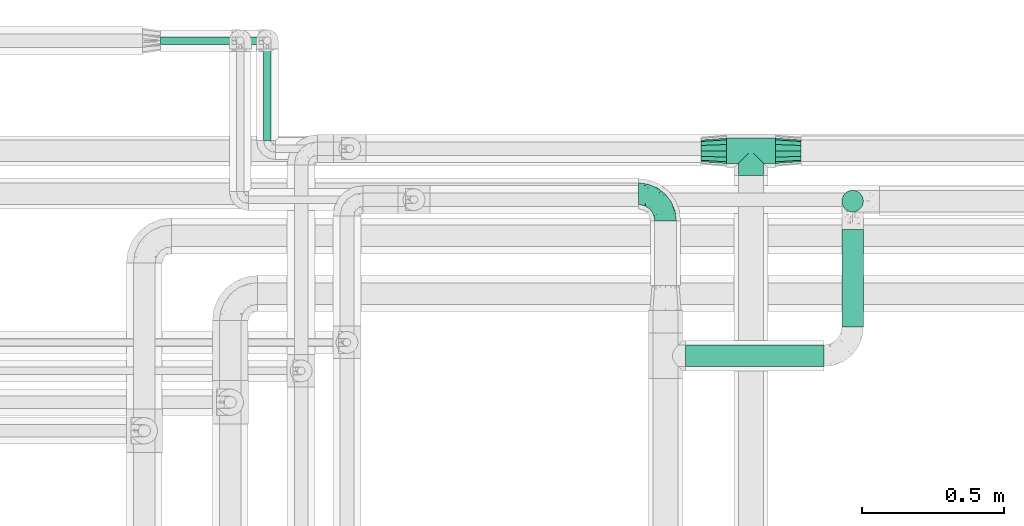
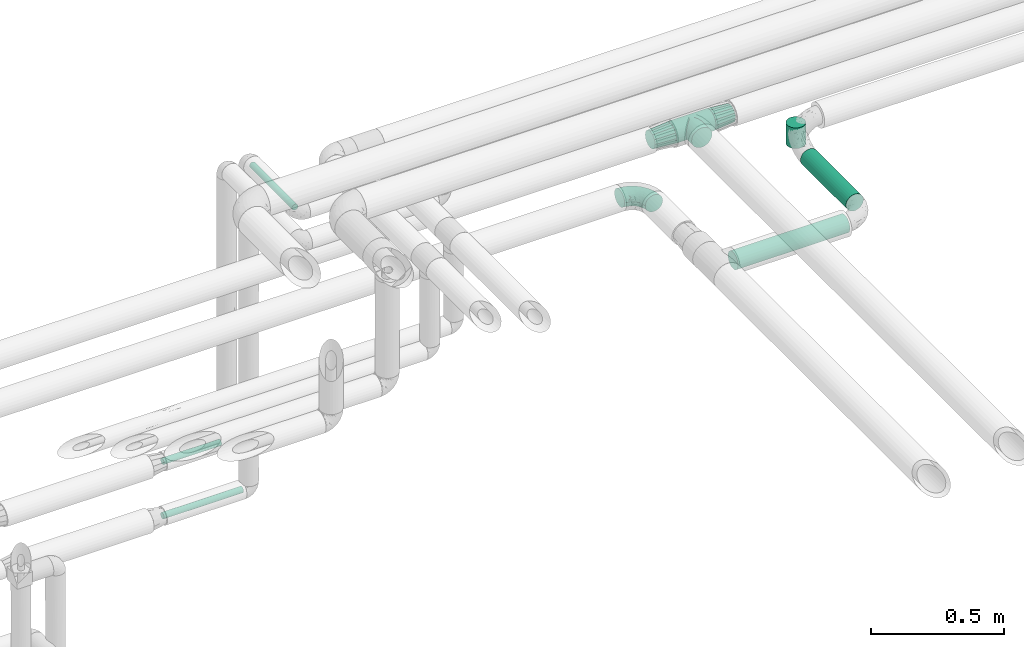
# One storey, part 653 of 827: 6 flow segments, 4 flow fittings.
"""IFC2X3 building model written with IfcOpenShell, lengths in millimetres."""

from ifc_helpers import new_model, entity, si_unit, converted_unit, derived_unit, direction, frame, origin, origin_2d_with_axis, place, context, subcontext, project, spatial, circle, extrude, faceted_brep, source, transform, mapped, material, type_object, type_shapes, element, save


model = new_model("IFC2X3")

# Units and contexts
model_context = context("Model", 3, precision=0.01, world=origin(), true_north=direction((6.12303176911189e-17, 1.0)))
body_context = subcontext(model_context, "Body", "Model", "MODEL_VIEW")
ifc_project = project(units=[si_unit("LENGTHUNIT", "METRE", prefix="MILLI"), si_unit("AREAUNIT", "SQUARE_METRE"), si_unit("VOLUMEUNIT", "CUBIC_METRE"), converted_unit("PLANEANGLEUNIT", "DEGREE", entity("IfcRatioMeasure", 0.0174532925199433), si_unit("PLANEANGLEUNIT", "RADIAN"), dimensions=[0, 0, 0, 0, 0, 0, 0]), si_unit("MASSUNIT", "GRAM", prefix="KILO"), derived_unit("MASSDENSITYUNIT", [(si_unit("MASSUNIT", "GRAM", prefix="KILO"), 1), (si_unit("LENGTHUNIT", "METRE"), -3)]), derived_unit("MOMENTOFINERTIAUNIT", [(si_unit("LENGTHUNIT", "METRE"), 4)]), si_unit("TIMEUNIT", "SECOND"), si_unit("FREQUENCYUNIT", "HERTZ"), si_unit("THERMODYNAMICTEMPERATUREUNIT", "DEGREE_CELSIUS"), derived_unit("THERMALTRANSMITTANCEUNIT", [(si_unit("MASSUNIT", "GRAM", prefix="KILO"), 1), (si_unit("THERMODYNAMICTEMPERATUREUNIT", "KELVIN"), -1), (si_unit("TIMEUNIT", "SECOND"), -3)]), derived_unit("VOLUMETRICFLOWRATEUNIT", [(si_unit("LENGTHUNIT", "METRE"), 3), (si_unit("TIMEUNIT", "SECOND"), -1)]), derived_unit("MASSFLOWRATEUNIT", [(si_unit("MASSUNIT", "GRAM", prefix="KILO"), 1), (si_unit("TIMEUNIT", "SECOND"), -1)]), derived_unit("ROTATIONALFREQUENCYUNIT", [(si_unit("TIMEUNIT", "SECOND"), -1)]), si_unit("ELECTRICCURRENTUNIT", "AMPERE"), si_unit("ELECTRICVOLTAGEUNIT", "VOLT"), si_unit("POWERUNIT", "WATT"), si_unit("FORCEUNIT", "NEWTON", prefix="KILO"), si_unit("ILLUMINANCEUNIT", "LUX"), si_unit("LUMINOUSFLUXUNIT", "LUMEN"), si_unit("LUMINOUSINTENSITYUNIT", "CANDELA"), derived_unit("USERDEFINED", [(si_unit("MASSUNIT", "GRAM", prefix="KILO"), -1), (si_unit("LENGTHUNIT", "METRE"), -2), (si_unit("TIMEUNIT", "SECOND"), 3), (si_unit("LUMINOUSFLUXUNIT", "LUMEN"), 1)]), derived_unit("LINEARVELOCITYUNIT", [(si_unit("LENGTHUNIT", "METRE"), 1), (si_unit("TIMEUNIT", "SECOND"), -1)]), si_unit("PRESSUREUNIT", "PASCAL"), derived_unit("USERDEFINED", [(si_unit("LENGTHUNIT", "METRE"), -2), (si_unit("MASSUNIT", "GRAM", prefix="KILO"), 1), (si_unit("TIMEUNIT", "SECOND"), -2)]), derived_unit("LINEARFORCEUNIT", [(si_unit("MASSUNIT", "GRAM", prefix="KILO"), 1), (si_unit("LENGTHUNIT", "METRE"), 1), (si_unit("TIMEUNIT", "SECOND"), -2), (si_unit("LENGTHUNIT", "METRE"), -1)]), derived_unit("PLANARFORCEUNIT", [(si_unit("MASSUNIT", "GRAM", prefix="KILO"), 1), (si_unit("LENGTHUNIT", "METRE"), 1), (si_unit("TIMEUNIT", "SECOND"), -2), (si_unit("LENGTHUNIT", "METRE"), -2)])], contexts=[model_context])

# Site, building, storey
site_placement = place(None, origin())
site = spatial("IfcSite", under=ifc_project, at=site_placement, CompositionType="ELEMENT")
building_placement = place(site_placement, origin())
building = spatial("IfcBuilding", under=site, at=building_placement, CompositionType="ELEMENT")
storey_placement = place(building_placement, frame((0.0, 0.0, 28200.0)))
storey = spatial("IfcBuildingStorey", under=building, at=storey_placement, Name="08", CompositionType="ELEMENT", Elevation=28200.0)

# Flow segments
pipe_segment_type_1 = type_object("IfcPipeSegmentType", PredefinedType="NOTDEFINED")
flow_segment_1_placement = place(storey_placement, frame((37818.3, 18348.79, 2860.49)))
element("IfcFlowSegment", 1, at=flow_segment_1_placement, inside=storey, type_object=pipe_segment_type_1, context=body_context, shape_type="SweptSolid", body=[
    extrude(circle(Radius=38.0, at=origin_2d_with_axis()), frame((486.93, 39.6, 39.6), z_axis=(-1.0, 0.0, 1.26378511103268e-05), x_axis=(0.0, 1.0, 0.0)), (0.0, 0.0, 1.0), 486.924860554591),
])
flow_segment_2_placement = place(storey_placement, frame((38365.63, 18488.39, 2860.49)))
element("IfcFlowSegment", 2, at=flow_segment_2_placement, inside=storey, type_object=pipe_segment_type_1, context=body_context, shape_type="SweptSolid", body=[
    extrude(circle(Radius=38.0, at=origin_2d_with_axis()), frame((39.6, 0.0, 39.6), z_axis=(0.0, 1.0, 0.0), x_axis=(1.0, 0.0, 0.0)), (0.0, 0.0, 1.0), 342.960612492096),
])
pipe_segment_type_2 = type_object("IfcPipeSegmentType", PredefinedType="NOTDEFINED")
flow_segment_3_placement = place(storey_placement, frame((35975.02, 19479.61, 1935.0)))
element("IfcFlowSegment", 3, at=flow_segment_3_placement, inside=storey, type_object=pipe_segment_type_2, context=body_context, shape_type="SweptSolid", body=[
    extrude(circle(Radius=13.4, at=origin_2d_with_axis()), frame((0.0, 15.0, 15.0), z_axis=(1.0, 0.0, 0.0), x_axis=(0.0, 1.0, 0.0)), (0.0, 0.0, 1.0), 250.900000000008),
])
flow_segment_4_placement = place(storey_placement, frame((35975.02, 19479.61, 1685.0)))
element("IfcFlowSegment", 4, at=flow_segment_4_placement, inside=storey, type_object=pipe_segment_type_2, context=body_context, shape_type="SweptSolid", body=[
    extrude(circle(Radius=13.4, at=origin_2d_with_axis()), frame((0.0, 15.0, 15.0), z_axis=(1.0, -1.51880238735498e-07, 0.0), x_axis=(1.51880238735498e-07, 1.0, 0.0)), (0.0, 0.0, 1.0), 345.900000000012),
])
flow_segment_5_placement = place(storey_placement, frame((36335.03, 19144.59, 3185.0)))
element("IfcFlowSegment", 5, at=flow_segment_5_placement, inside=storey, type_object=pipe_segment_type_2, context=body_context, shape_type="SweptSolid", body=[
    extrude(circle(Radius=13.4, at=origin_2d_with_axis()), frame((15.0, 0.0, 15.0), z_axis=(2.65845070723248e-08, 1.0, 0.0), x_axis=(-1.0, 2.65845070723248e-08, 0.0)), (0.0, 0.0, 1.0), 320.918318490439),
])
flow_segment_6_placement = place(storey_placement, frame((38365.88, 18892.0, 2905.0)))
element("IfcFlowSegment", 6, at=flow_segment_6_placement, inside=storey, type_object=pipe_segment_type_2, context=body_context, shape_type="SweptSolid", body=[
    extrude(circle(Radius=37.75, at=origin_2d_with_axis()), frame((39.35, 39.35, 0.0)), (0.0, 0.0, 1.0), 95.0837766877731),
])

# Flow fittings
ifc_material = material()
pipe_fitting_type_1 = type_object("IfcPipeFittingType", Name="ADSK_1", PredefinedType="NOTDEFINED", material=ifc_material)
shared_shape_1 = source(origin(), body_context, "Body", "Brep", [
    faceted_brep([(-95.0, 19.02, -32.95), (-95.0, 9.85, -36.75), (-95.0, 0.0, -38.05), (-95.0, -9.85, -36.75), (-95.0, -19.03, -32.95), (-95.0, -26.91, -26.91), (-95.0, -32.95, -19.03), (-95.0, -36.75, -9.85), (-95.0, -38.05, 0.0), (-95.0, -36.75, 9.85), (-95.0, -32.95, 19.02), (-95.0, -26.91, 26.91), (-95.0, -19.03, 32.95), (-95.0, -9.85, 36.75), (-95.0, 0.0, 38.05), (-95.0, 9.85, 36.75), (-95.0, 19.02, 32.95), (-95.0, 26.91, 26.91), (-95.0, 32.95, 19.02), (-95.0, 36.75, 9.85), (-95.0, 38.05, 0.0), (-95.0, 36.75, -9.85), (-95.0, 32.95, -19.03), (-95.0, 26.91, -26.91), (0.0, 95.0, -38.05), (-9.85, 95.0, -36.75), (-19.02, 95.0, -32.95), (-26.91, 95.0, -26.91), (-32.95, 95.0, -19.03), (-36.75, 95.0, -9.85), (-38.05, 95.0, 0.0), (-36.75, 95.0, 9.85), (-32.95, 95.0, 19.02), (-26.91, 95.0, 26.91), (-19.02, 95.0, 32.95), (-9.85, 95.0, 36.75), (0.0, 95.0, 38.05), (9.85, 95.0, 36.75), (19.03, 95.0, 32.95), (26.91, 95.0, 26.91), (32.95, 95.0, 19.02), (36.75, 95.0, 9.85), (38.05, 95.0, 0.0), (36.75, 95.0, -9.85), (32.95, 95.0, -19.03), (26.91, 95.0, -26.91), (19.03, 95.0, -32.95), (9.85, 95.0, -36.75), (-7.99, -4.96, 6.3), (-0.92, 0.92, 0.0), (4.62, 8.1, 8.01), (-76.19, -35.57, 0.0), (-64.32, -32.32, 12.43), (20.51, 62.45, 28.68), (-60.56, -33.52, 0.0), (-70.4, -13.47, 34.42), (-39.61, -5.88, 32.32), (-49.6, 2.07, 37.1), (-70.34, -28.81, 21.71), (14.64, 40.81, 26.5), (5.88, 39.61, 32.32), (3.59, 20.77, 25.31), (-40.45, 68.06, 16.75), (-62.45, -20.51, 28.68), (-44.52, -26.87, 0.0), (-28.47, -20.22, 0.0), (-26.43, -17.83, 8.75), (-76.1, 39.63, 10.76), (-72.74, 37.58, 18.19), (-60.35, 46.18, 14.61), (-13.4, 13.4, 32.12), (-20.77, -3.59, 25.31), (-14.66, 81.47, 35.56), (-6.22, 71.26, 37.92), (-57.5, 42.48, 22.79), (-15.0, 34.74, 37.7), (-27.1, 12.08, 36.05), (-9.2, 28.81, 35.63), (-79.98, 23.7, 30.95), (-73.68, -4.3, 37.48), (-30.74, 21.67, 37.97), (-62.36, 47.59, 6.79), (-72.71, 32.83, 24.69), (-67.42, 7.02, 37.95), (-32.13, 75.27, 24.51), (-43.46, 51.47, 26.26), (-24.98, 73.15, 31.29), (20.59, 41.28, 19.85), (7.79, 16.09, 15.86), (-73.21, 42.39, 0.0), (-54.73, 54.73, 0.0), (-73.44, 15.79, 35.79), (-5.94, 4.32, 20.43), (28.81, 70.34, 21.71), (32.32, 64.32, 12.43), (-53.59, 26.2, 35.09), (-52.02, 19.31, 37.21), (21.38, 33.53, 10.34), (26.87, 44.52, 0.0), (-48.28, 12.14, 38.05), (4.3, 73.68, 37.48), (-44.08, -25.52, 12.79), (-41.28, -20.59, 19.85), (35.57, 76.19, 0.0), (-47.26, 54.3, 20.18), (-47.4, 61.99, 8.58), (-42.39, 73.21, 0.0), (-39.67, 78.86, 7.21), (-45.69, 36.84, 33.11), (-32.83, 50.13, 33.35), (13.47, 70.4, 34.42), (-18.25, 63.73, 36.07), (-40.63, -13.75, 27.22), (-16.63, 46.37, 37.95), (-53.47, 38.79, 28.59), (-26.07, 48.54, 36.15), (-34.51, 34.51, 36.86), (-2.07, 49.6, 37.1), (-22.79, -10.49, 19.23), (-61.73, 28.67, 31.87), (9.65, 14.7, 0.0), (20.22, 28.47, 0.0), (33.52, 60.56, 0.0), (-11.42, -5.44, 13.25), (-14.7, -9.65, 0.0), (-81.47, 14.66, -35.56), (-62.45, -20.51, -28.68), (-71.26, 6.22, -37.92), (-75.27, 32.13, -24.51), (-73.15, 24.98, -31.29), (13.47, 70.4, -34.42), (5.88, 39.61, -32.32), (-2.07, 49.6, -37.1), (-78.86, 39.67, -7.21), (-70.4, -13.47, -34.42), (-39.61, -5.88, -32.32), (-61.99, 47.4, -8.58), (32.32, 64.32, -12.43), (28.81, 70.34, -21.71), (-63.73, 18.25, -36.07), (-50.13, 32.83, -33.35), (4.3, 73.68, -37.48), (-7.02, 67.42, -37.95), (-39.63, 76.1, -10.76), (-46.18, 60.35, -14.61), (-47.59, 62.36, -6.79), (-64.32, -32.32, -12.43), (-26.2, 53.59, -35.09), (-15.79, 73.44, -35.79), (-19.31, 52.02, -37.21), (-37.58, 72.74, -18.19), (-70.34, -28.81, -21.71), (-42.48, 57.5, -22.79), (-38.79, 53.47, -28.59), (-51.47, 43.46, -26.26), (-32.83, 72.71, -24.69), (-46.37, 16.63, -37.95), (-73.68, -4.3, -37.48), (-41.28, -20.59, -19.85), (-44.08, -25.52, -12.79), (13.75, 40.63, -27.22), (20.51, 62.45, -28.68), (-68.06, 40.45, -16.75), (-54.3, 47.26, -20.18), (-12.14, 48.28, -38.05), (-21.67, 30.74, -37.97), (-36.84, 45.69, -33.11), (-11.42, -5.44, -13.25), (7.79, 16.09, -15.86), (4.62, 8.1, -8.01), (-23.7, 79.98, -30.95), (-26.43, -17.83, -8.75), (-7.99, -4.96, -6.3), (-40.81, -14.64, -26.5), (-20.77, -3.59, -25.31), (-34.74, 15.0, -37.7), (-12.08, 27.1, -36.05), (-28.81, 9.2, -35.63), (-22.79, -10.49, -19.23), (21.38, 33.53, -10.34), (20.59, 41.28, -19.85), (-48.54, 26.07, -36.15), (-49.6, 2.07, -37.1), (-13.4, 13.4, -32.12), (3.59, 20.77, -25.31), (-28.67, 61.73, -31.87), (-34.51, 34.51, -36.86), (-5.94, 4.32, -20.43)], [[[0, 1, 2, 3, 4, 5, 6, 7, 8, 9, 10, 11, 12, 13, 14, 15, 16, 17, 18, 19, 20, 21, 22, 23]], [[24, 25, 26, 27, 28, 29, 30, 31, 32, 33, 34, 35, 36, 37, 38, 39, 40, 41, 42, 43, 44, 45, 46, 47]], [[48, 49, 50]], [[51, 52, 9]], [[53, 39, 38]], [[9, 52, 10]], [[54, 52, 51]], [[55, 56, 57]], [[11, 10, 58]], [[59, 60, 61]], [[32, 31, 62]], [[63, 12, 11]], [[63, 55, 12]], [[64, 65, 66]], [[67, 68, 69]], [[70, 56, 71]], [[35, 72, 73]], [[69, 68, 74]], [[75, 76, 77]], [[16, 78, 17]], [[13, 79, 14]], [[76, 75, 80]], [[67, 69, 81]], [[18, 17, 82]], [[14, 79, 83]], [[20, 19, 67]], [[84, 85, 86]], [[87, 61, 88]], [[89, 81, 90]], [[18, 82, 68]], [[15, 91, 16]], [[14, 83, 15]], [[71, 92, 61]], [[17, 78, 82]], [[93, 87, 94]], [[95, 91, 96]], [[97, 98, 94]], [[86, 72, 34]], [[96, 99, 80]], [[37, 36, 100]], [[40, 39, 93]], [[40, 94, 41]], [[64, 66, 101]], [[93, 94, 40]], [[58, 102, 63]], [[94, 103, 41]], [[94, 87, 97]], [[104, 69, 74]], [[34, 33, 86]], [[105, 69, 104]], [[52, 58, 10]], [[106, 107, 30]], [[108, 109, 85]], [[105, 106, 90]], [[53, 110, 60]], [[86, 111, 72]], [[86, 109, 111]], [[33, 84, 86]], [[12, 55, 13]], [[112, 56, 63]], [[110, 38, 37]], [[34, 72, 35]], [[36, 35, 73]], [[111, 113, 73]], [[105, 107, 106]], [[110, 53, 38]], [[74, 114, 85]], [[91, 15, 83]], [[105, 90, 81]], [[107, 62, 31]], [[33, 32, 84]], [[115, 109, 116]], [[111, 115, 113]], [[100, 73, 117]], [[56, 55, 63]], [[79, 55, 57]], [[102, 118, 112]], [[56, 70, 76]], [[100, 110, 37]], [[117, 77, 60]], [[117, 60, 110]], [[60, 70, 61]], [[58, 52, 101]], [[63, 11, 58]], [[39, 53, 93]], [[87, 93, 53]], [[96, 91, 83]], [[78, 91, 119]], [[32, 62, 84]], [[84, 62, 104]], [[86, 85, 109]], [[85, 114, 108]], [[80, 113, 116]], [[117, 73, 113]], [[80, 116, 96]], [[80, 57, 76]], [[71, 112, 118]], [[61, 87, 59]], [[62, 107, 105]], [[97, 120, 121]], [[70, 71, 61]], [[71, 118, 92]], [[73, 100, 36]], [[110, 100, 117]], [[55, 79, 13]], [[83, 79, 57]], [[96, 83, 99]], [[116, 108, 95]], [[50, 97, 88]], [[97, 87, 88]], [[50, 49, 120]], [[122, 94, 98]], [[89, 20, 67]], [[105, 81, 69]], [[89, 67, 81]], [[68, 19, 18]], [[68, 67, 19]], [[74, 68, 82]], [[114, 82, 119]], [[74, 85, 104]], [[82, 114, 74]], [[114, 119, 108]], [[95, 108, 119]], [[116, 109, 108]], [[123, 48, 50]], [[97, 50, 120]], [[123, 50, 88]], [[91, 95, 119]], [[116, 95, 96]], [[84, 104, 85]], [[104, 62, 105]], [[83, 57, 99]], [[57, 80, 99]], [[66, 48, 123]], [[66, 124, 48]], [[118, 66, 123]], [[124, 66, 65]], [[66, 118, 101]], [[54, 64, 52]], [[124, 49, 48]], [[30, 107, 31]], [[91, 78, 16]], [[82, 78, 119]], [[56, 76, 57]], [[77, 76, 70]], [[60, 77, 70]], [[77, 117, 75]], [[117, 113, 75]], [[113, 80, 75]], [[9, 8, 51]], [[103, 94, 122]], [[103, 42, 41]], [[73, 72, 111]], [[113, 115, 116]], [[111, 109, 115]], [[102, 112, 63]], [[71, 56, 112]], [[118, 102, 101]], [[92, 123, 88]], [[123, 92, 118]], [[61, 92, 88]], [[87, 53, 59]], [[60, 59, 53]], [[97, 121, 98]], [[58, 101, 102]], [[64, 101, 52]], [[125, 1, 0]], [[126, 5, 4]], [[2, 1, 127]], [[1, 125, 127]], [[128, 129, 23]], [[130, 131, 132]], [[89, 133, 20]], [[126, 134, 135]], [[136, 89, 90]], [[137, 138, 44]], [[139, 129, 140]], [[24, 141, 142]], [[143, 144, 145]], [[125, 129, 139]], [[6, 146, 7]], [[147, 148, 149]], [[146, 51, 7]], [[143, 150, 144]], [[146, 6, 151]], [[152, 153, 154]], [[126, 4, 134]], [[0, 23, 129]], [[28, 155, 150]], [[43, 42, 103]], [[54, 146, 64]], [[139, 156, 127]], [[157, 3, 2]], [[151, 158, 159]], [[160, 131, 161]], [[22, 21, 162]], [[136, 144, 163]], [[149, 164, 165]], [[24, 142, 25]], [[166, 140, 154]], [[154, 129, 128]], [[143, 30, 29]], [[167, 168, 169]], [[155, 28, 27]], [[26, 170, 27]], [[171, 167, 172]], [[26, 25, 148]], [[27, 170, 155]], [[173, 135, 174]], [[144, 150, 152]], [[175, 176, 177]], [[24, 47, 141]], [[45, 161, 46]], [[148, 25, 142]], [[176, 175, 165]], [[64, 159, 171]], [[138, 45, 44]], [[130, 46, 161]], [[137, 44, 43]], [[178, 159, 158]], [[137, 103, 122]], [[163, 144, 152]], [[136, 133, 89]], [[103, 137, 43]], [[6, 5, 151]], [[178, 158, 173]], [[134, 4, 3]], [[178, 173, 174]], [[137, 98, 179]], [[145, 90, 106]], [[138, 180, 161]], [[46, 130, 47]], [[136, 90, 145]], [[133, 162, 21]], [[23, 22, 128]], [[139, 140, 181]], [[139, 181, 156]], [[157, 127, 182]], [[157, 134, 3]], [[182, 177, 135]], [[182, 135, 134]], [[135, 183, 174]], [[131, 130, 161]], [[141, 130, 132]], [[160, 180, 184]], [[131, 183, 176]], [[5, 126, 151]], [[158, 151, 126]], [[180, 138, 137]], [[161, 45, 138]], [[149, 148, 142]], [[170, 148, 185]], [[22, 162, 128]], [[128, 162, 163]], [[129, 154, 140]], [[154, 153, 166]], [[165, 156, 186]], [[182, 127, 156]], [[165, 186, 149]], [[165, 132, 176]], [[131, 184, 183]], [[187, 167, 178]], [[184, 168, 187]], [[167, 169, 172]], [[184, 180, 168]], [[174, 183, 184]], [[127, 157, 2]], [[134, 157, 182]], [[130, 141, 47]], [[142, 141, 132]], [[149, 142, 164]], [[186, 166, 147]], [[180, 179, 168]], [[169, 179, 120]], [[137, 179, 180]], [[179, 121, 120]], [[106, 30, 143]], [[136, 145, 144]], [[106, 143, 145]], [[150, 29, 28]], [[150, 143, 29]], [[152, 150, 155]], [[153, 155, 185]], [[152, 154, 163]], [[155, 153, 152]], [[153, 185, 166]], [[147, 166, 185]], [[186, 140, 166]], [[169, 120, 49]], [[169, 49, 172]], [[179, 169, 168]], [[148, 147, 185]], [[186, 147, 149]], [[128, 163, 154]], [[163, 162, 136]], [[142, 132, 164]], [[132, 165, 164]], [[171, 124, 65]], [[124, 171, 172]], [[64, 146, 159]], [[171, 159, 178]], [[171, 65, 64]], [[172, 49, 124]], [[162, 133, 136]], [[20, 133, 21]], [[148, 170, 26]], [[155, 170, 185]], [[131, 176, 132]], [[177, 176, 183]], [[135, 177, 183]], [[177, 182, 175]], [[182, 156, 175]], [[156, 165, 175]], [[51, 146, 54]], [[51, 8, 7]], [[129, 125, 0]], [[127, 125, 139]], [[140, 186, 181]], [[156, 181, 186]], [[158, 126, 173]], [[135, 173, 126]], [[187, 178, 174]], [[171, 178, 167]], [[184, 187, 174]], [[167, 187, 168]], [[180, 160, 161]], [[184, 131, 160]], [[98, 137, 122]], [[98, 121, 179]], [[151, 159, 146]]]),
])
type_shapes(pipe_fitting_type_1, [shared_shape_1])
flow_fitting_1_placement = place(storey_placement, frame((37748.3, 18957.24, 2900.08), z_axis=(0.0, 2.73047951780172e-05, 1.0), x_axis=(0.0, 1.0, -2.73047951780172e-05)))
element("IfcFlowFitting", 7, at=flow_fitting_1_placement, inside=storey, type_object=pipe_fitting_type_1, material=ifc_material, Name="ADSK_1", ObjectType="ADSK_1", context=body_context, shape_type="MappedRepresentation", body=[
    mapped(shared_shape_1, transform((0.0, 0.0, 0.0), scale=1.0)),
])
pipe_fitting_type_2 = type_object("IfcPipeFittingType", Name="ADSK_1", PredefinedType="NOTDEFINED", material=ifc_material)
shared_shape_2 = source(origin(), body_context, "Body", "Brep", [
    faceted_brep([(-86.0, 22.22, -38.49), (-86.0, 11.5, -42.94), (-86.0, 0.0, -44.45), (-86.0, -11.5, -42.94), (-86.0, -22.23, -38.49), (-86.0, -26.83, -34.96), (-86.0, -31.43, -31.43), (-86.0, -34.96, -26.83), (-86.0, -38.49, -22.23), (-86.0, -40.72, -16.86), (-86.0, -42.94, -11.5), (-86.0, -44.45, 0.0), (-86.0, -42.94, 11.5), (-86.0, -40.72, 16.86), (-86.0, -38.49, 22.22), (-86.0, -34.96, 26.83), (-86.0, -31.43, 31.43), (-86.0, -26.83, 34.96), (-86.0, -22.23, 38.49), (-86.0, -11.5, 42.94), (-86.0, 0.0, 44.45), (-86.0, 11.5, 42.94), (-86.0, 22.22, 38.49), (-86.0, 31.43, 31.43), (-86.0, 38.49, 22.22), (-86.0, 42.94, 11.5), (-86.0, 44.45, 0.0), (-86.0, 42.94, -11.5), (-86.0, 38.49, -22.23), (-86.0, 31.43, -31.43), (86.0, 0.0, -44.45), (86.0, 11.5, -42.94), (86.0, 22.22, -38.49), (86.0, 31.43, -31.43), (86.0, 38.49, -22.23), (86.0, 42.94, -11.5), (86.0, 44.45, 0.0), (86.0, 42.94, 11.5), (86.0, 38.49, 22.22), (86.0, 31.43, 31.43), (86.0, 22.22, 38.49), (86.0, 11.5, 42.94), (86.0, 0.0, 44.45), (86.0, -11.5, 42.94), (86.0, -22.23, 38.49), (86.0, -26.83, 34.96), (86.0, -31.43, 31.43), (86.0, -34.96, 26.83), (86.0, -38.49, 22.22), (86.0, -40.72, 16.86), (86.0, -42.94, 11.5), (86.0, -44.45, 0.0), (86.0, -42.94, -11.5), (86.0, -40.72, -16.86), (86.0, -38.49, -22.23), (86.0, -34.96, -26.83), (86.0, -31.43, -31.43), (86.0, -26.83, -34.96), (86.0, -22.23, -38.49), (86.0, -11.5, -42.94), (43.21, -43.21, 10.43), (44.45, -44.45, 0.0), (-43.21, -43.21, 10.43), (-44.45, -44.45, 0.0), (41.49, -41.49, 15.14), (39.77, -39.77, 19.85), (21.97, -21.97, 38.64), (34.75, -34.75, 27.71), (28.69, -28.69, 33.95), (-41.49, -41.49, 15.14), (-39.77, -39.77, 19.85), (-21.97, -21.97, 38.64), (-34.75, -34.75, 27.71), (-28.69, -28.69, 33.95), (-14.84, -14.84, 41.9), (7.47, -7.47, 43.82), (14.84, -14.84, 41.9), (0.0, 0.0, 44.45), (-7.47, -7.47, 43.82), (7.47, -7.47, -43.82), (0.0, 0.0, -44.45), (14.84, -14.84, -41.9), (-28.69, -28.69, -33.95), (-7.47, -7.47, -43.82), (-41.49, -41.49, -15.14), (-43.21, -43.21, -10.43), (-34.75, -34.75, -27.71), (-14.84, -14.84, -41.9), (21.97, -21.97, -38.64), (28.69, -28.69, -33.95), (-39.77, -39.77, -19.85), (34.75, -34.75, -27.71), (43.21, -43.21, -10.43), (41.49, -41.49, -15.14), (39.77, -39.77, -19.85), (-21.97, -21.97, -38.64), (31.43, -86.0, -31.43), (38.49, -86.0, -22.23), (42.94, -86.0, -11.5), (44.45, -86.0, 0.0), (42.94, -86.0, 11.5), (38.49, -86.0, 22.22), (31.43, -86.0, 31.43), (22.23, -86.0, 38.49), (11.5, -86.0, 42.94), (0.0, -86.0, 44.45), (-11.5, -86.0, 42.94), (-22.22, -86.0, 38.49), (-31.43, -86.0, 31.43), (-38.49, -86.0, 22.22), (-42.94, -86.0, 11.5), (-44.45, -86.0, 0.0), (-42.94, -86.0, -11.5), (-38.49, -86.0, -22.23), (-31.43, -86.0, -31.43), (-22.22, -86.0, -38.49), (-11.5, -86.0, -42.94), (0.0, -86.0, -44.45), (11.5, -86.0, -42.94), (22.23, -86.0, -38.49)], [[[0, 1, 2, 3, 4, 5, 6, 7, 8, 9, 10, 11, 12, 13, 14, 15, 16, 17, 18, 19, 20, 21, 22, 23, 24, 25, 26, 27, 28, 29]], [[30, 31, 32, 33, 34, 35, 36, 37, 38, 39, 40, 41, 42, 43, 44, 45, 46, 47, 48, 49, 50, 51, 52, 53, 54, 55, 56, 57, 58, 59]], [[51, 50, 60]], [[60, 61, 51]], [[62, 11, 63]], [[50, 49, 64]], [[49, 48, 65]], [[44, 66, 45]], [[46, 67, 48, 47]], [[67, 46, 68]], [[48, 67, 65]], [[68, 46, 45]], [[12, 69, 13]], [[70, 13, 69]], [[11, 62, 12]], [[12, 62, 69]], [[71, 18, 17]], [[72, 73, 16]], [[72, 16, 15, 14]], [[16, 73, 17]], [[71, 74, 18]], [[72, 14, 70]], [[49, 65, 64]], [[45, 66, 68]], [[43, 42, 75]], [[50, 64, 60]], [[66, 44, 76]], [[75, 76, 43]], [[75, 42, 77]], [[78, 77, 20]], [[76, 44, 43]], [[24, 23, 39, 38]], [[25, 24, 38, 37]], [[22, 21, 41, 40]], [[23, 22, 40, 39]], [[41, 21, 20, 77, 42]], [[26, 25, 37, 36]], [[70, 14, 13]], [[78, 19, 74]], [[19, 78, 20]], [[19, 18, 74]], [[71, 17, 73]], [[29, 28, 34, 33]], [[27, 35, 34, 28]], [[26, 36, 35, 27]], [[0, 29, 33, 32]], [[30, 59, 79]], [[31, 30, 80, 2, 1]], [[79, 59, 81]], [[82, 6, 5]], [[32, 31, 1, 0]], [[59, 58, 81]], [[30, 79, 80]], [[80, 83, 2]], [[10, 84, 85]], [[86, 8, 7, 6]], [[83, 87, 3]], [[2, 83, 3]], [[87, 4, 3]], [[88, 57, 89]], [[57, 56, 89]], [[9, 90, 84]], [[88, 58, 57]], [[91, 89, 56]], [[55, 54, 91, 56]], [[58, 88, 81]], [[52, 92, 93]], [[92, 52, 51]], [[94, 53, 93]], [[61, 92, 51]], [[85, 63, 11]], [[54, 94, 91]], [[82, 5, 95]], [[52, 93, 53]], [[5, 4, 95]], [[6, 82, 86]], [[94, 54, 53]], [[95, 4, 87]], [[10, 9, 84]], [[90, 9, 8]], [[10, 85, 11]], [[90, 8, 86]], [[96, 97, 98, 99, 100, 101, 102, 103, 104, 105, 106, 107, 108, 109, 110, 111, 112, 113, 114, 115, 116, 117, 118, 119]], [[62, 63, 111]], [[110, 62, 111]], [[108, 107, 73]], [[72, 109, 108]], [[70, 110, 109]], [[74, 107, 106]], [[110, 70, 69, 62]], [[73, 72, 108]], [[70, 109, 72]], [[74, 71, 107]], [[105, 77, 78]], [[74, 106, 78]], [[73, 107, 71]], [[78, 106, 105]], [[75, 105, 104]], [[103, 76, 104]], [[101, 100, 65]], [[67, 102, 101]], [[68, 103, 102]], [[60, 100, 99]], [[68, 66, 103]], [[76, 75, 104]], [[66, 76, 103]], [[61, 60, 99]], [[65, 67, 101]], [[100, 60, 64, 65]], [[68, 102, 67]], [[105, 75, 77]], [[61, 99, 92]], [[98, 92, 99]], [[96, 119, 89]], [[94, 98, 97]], [[96, 91, 97]], [[81, 119, 118]], [[98, 94, 93, 92]], [[89, 91, 96]], [[94, 97, 91]], [[81, 88, 119]], [[117, 80, 79]], [[81, 118, 79]], [[89, 119, 88]], [[79, 118, 117]], [[83, 117, 116]], [[115, 87, 116]], [[113, 112, 90]], [[86, 114, 113]], [[82, 115, 114]], [[85, 112, 111]], [[82, 95, 115]], [[87, 83, 116]], [[95, 87, 115]], [[63, 85, 111]], [[90, 86, 113]], [[112, 85, 84, 90]], [[82, 114, 86]], [[117, 83, 80]]]),
])
type_shapes(pipe_fitting_type_2, [shared_shape_2])
flow_fitting_2_placement = place(storey_placement, frame((38048.3, 19107.72, 3000.0)))
element("IfcFlowFitting", 8, at=flow_fitting_2_placement, inside=storey, type_object=pipe_fitting_type_2, material=ifc_material, Name="ADSK_1", ObjectType="ADSK_1", context=body_context, shape_type="MappedRepresentation", body=[
    mapped(shared_shape_2, transform((0.0, 0.0, 0.0), scale=1.0)),
])
pipe_fitting_type_3 = type_object("IfcPipeFittingType", Name="ADSK_1", PredefinedType="NOTDEFINED", material=ifc_material)
shared_shape_3 = source(origin(), body_context, "Body", "Brep", [
    faceted_brep([(89.0, -44.45, 0.0), (89.0, -41.96, -9.31), (89.0, -38.49, -22.22), (89.0, -30.36, -30.36), (89.0, -22.23, -38.49), (89.0, -11.11, -41.47), (89.0, 0.0, -44.45), (89.0, 11.11, -41.47), (89.0, 22.22, -38.49), (89.0, 30.36, -30.36), (89.0, 38.49, -22.22), (89.0, 41.96, -9.31), (89.0, 44.45, 0.0), (89.0, 41.96, 9.31), (89.0, 38.49, 22.23), (89.0, 30.36, 30.36), (89.0, 22.22, 38.49), (89.0, 11.11, 41.47), (89.0, 0.0, 44.45), (89.0, -11.11, 41.47), (89.0, -22.23, 38.49), (89.0, -30.36, 30.36), (89.0, -38.49, 22.23), (89.0, -41.96, 9.31), (0.0, 38.05, 0.0), (0.0, 35.5, -9.51), (0.0, 32.95, -19.02), (0.0, 25.99, -25.99), (0.0, 19.02, -32.95), (0.0, 9.51, -35.5), (0.0, 0.0, -38.05), (0.0, -9.51, -35.5), (0.0, -19.03, -32.95), (0.0, -25.99, -25.99), (0.0, -32.95, -19.02), (0.0, -35.5, -9.51), (0.0, -38.05, 0.0), (0.0, -35.5, 9.51), (0.0, -32.95, 19.03), (0.0, -25.99, 25.99), (0.0, -19.03, 32.95), (0.0, -9.51, 35.5), (0.0, 0.0, 38.05), (0.0, 9.51, 35.5), (0.0, 19.03, 32.95), (0.0, 25.99, 25.99), (0.0, 32.95, 19.03), (0.0, 35.5, 9.51)], [[[0, 1, 2, 3, 4, 5, 6, 7, 8, 9, 10, 11, 12, 13, 14, 15, 16, 17, 18, 19, 20, 21, 22, 23]], [[24, 25, 26, 27, 28, 29, 30, 31, 32, 33, 34, 35, 36, 37, 38, 39, 40, 41, 42, 43, 44, 45, 46, 47]], [[2, 1, 0, 36, 35, 34]], [[28, 8, 7, 6, 30, 29]], [[32, 4, 3, 2, 34, 33]], [[5, 4, 32, 31, 30, 6]], [[10, 26, 25, 24, 12, 11]], [[9, 8, 28, 27, 26, 10]], [[14, 13, 12, 24, 47, 46]], [[40, 20, 19, 18, 42, 41]], [[44, 16, 15, 14, 46, 45]], [[17, 16, 44, 43, 42, 18]], [[22, 38, 37, 36, 0, 23]], [[21, 20, 40, 39, 38, 22]]]),
])
type_shapes(pipe_fitting_type_3, [shared_shape_3])
flow_fitting_3_placement = place(storey_placement, frame((37873.3, 19107.72, 3000.0)))
element("IfcFlowFitting", 9, at=flow_fitting_3_placement, inside=storey, type_object=pipe_fitting_type_3, material=ifc_material, Name="ADSK_1", ObjectType="ADSK_1", context=body_context, shape_type="MappedRepresentation", body=[
    mapped(shared_shape_3, transform((0.0, 0.0, 0.0), scale=1.0)),
])
pipe_fitting_type_4 = type_object("IfcPipeFittingType", Name="ADSK_1", PredefinedType="NOTDEFINED", material=ifc_material)
shared_shape_4 = source(origin(), body_context, "Body", "Brep", [
    faceted_brep([(89.0, 38.05, 0.0), (89.0, 35.5, 9.51), (89.0, 32.95, 19.03), (89.0, 25.99, 25.99), (89.0, 19.02, 32.95), (89.0, 9.51, 35.5), (89.0, 0.0, 38.05), (89.0, -9.51, 35.5), (89.0, -19.03, 32.95), (89.0, -25.99, 25.99), (89.0, -32.95, 19.03), (89.0, -35.5, 9.51), (89.0, -38.05, 0.0), (89.0, -35.5, -9.51), (89.0, -32.95, -19.02), (89.0, -25.99, -25.99), (89.0, -19.03, -32.95), (89.0, -9.51, -35.5), (89.0, 0.0, -38.05), (89.0, 9.51, -35.5), (89.0, 19.02, -32.95), (89.0, 25.99, -25.99), (89.0, 32.95, -19.03), (89.0, 35.5, -9.51), (0.0, -38.49, 22.22), (0.0, -30.36, 30.36), (0.0, -22.22, 38.49), (0.0, -11.11, 41.47), (0.0, 0.0, 44.45), (0.0, 11.11, 41.47), (0.0, 22.23, 38.49), (0.0, 30.36, 30.36), (0.0, 38.49, 22.22), (0.0, 41.96, 9.31), (0.0, 44.45, 0.0), (0.0, 41.47, -11.11), (0.0, 38.49, -22.23), (0.0, 30.36, -30.36), (0.0, 22.23, -38.49), (0.0, 11.11, -41.47), (0.0, 0.0, -44.45), (0.0, -11.11, -41.47), (0.0, -22.23, -38.49), (0.0, -30.36, -30.36), (0.0, -38.49, -22.23), (0.0, -41.96, -9.31), (0.0, -44.45, 0.0), (0.0, -41.47, 11.11)], [[[0, 1, 2, 3, 4, 5, 6, 7, 8, 9, 10, 11, 12, 13, 14, 15, 16, 17, 18, 19, 20, 21, 22, 23]], [[24, 25, 26, 27, 28, 29, 30, 31, 32, 33, 34, 35, 36, 37, 38, 39, 40, 41, 42, 43, 44, 45, 46, 47]], [[23, 22, 36, 35, 34, 0]], [[39, 38, 20, 19, 18, 40]], [[38, 37, 36, 22, 21, 20]], [[43, 42, 16, 15, 14, 44]], [[41, 40, 18, 17, 16, 42]], [[12, 46, 45, 44, 14, 13]], [[11, 10, 24, 47, 46, 12]], [[27, 26, 8, 7, 6, 28]], [[26, 25, 24, 10, 9, 8]], [[31, 30, 4, 3, 2, 32]], [[29, 28, 6, 5, 4, 30]], [[0, 34, 33, 32, 2, 1]]]),
])
type_shapes(pipe_fitting_type_4, [shared_shape_4])
flow_fitting_4_placement = place(storey_placement, frame((38134.3, 19107.72, 3000.0)))
element("IfcFlowFitting", 10, at=flow_fitting_4_placement, inside=storey, type_object=pipe_fitting_type_4, material=ifc_material, Name="ADSK_1", ObjectType="ADSK_1", context=body_context, shape_type="MappedRepresentation", body=[
    mapped(shared_shape_4, transform((0.0, 0.0, 0.0), scale=1.0)),
])

save(model, "model.ifc")
